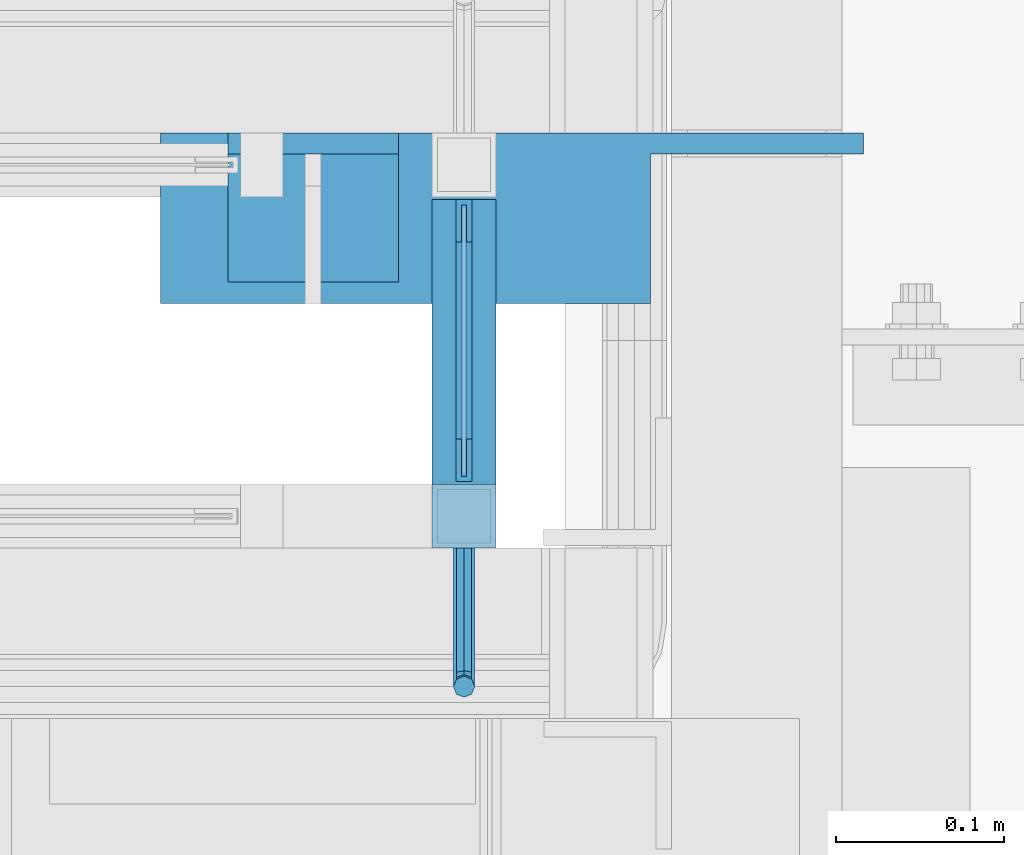
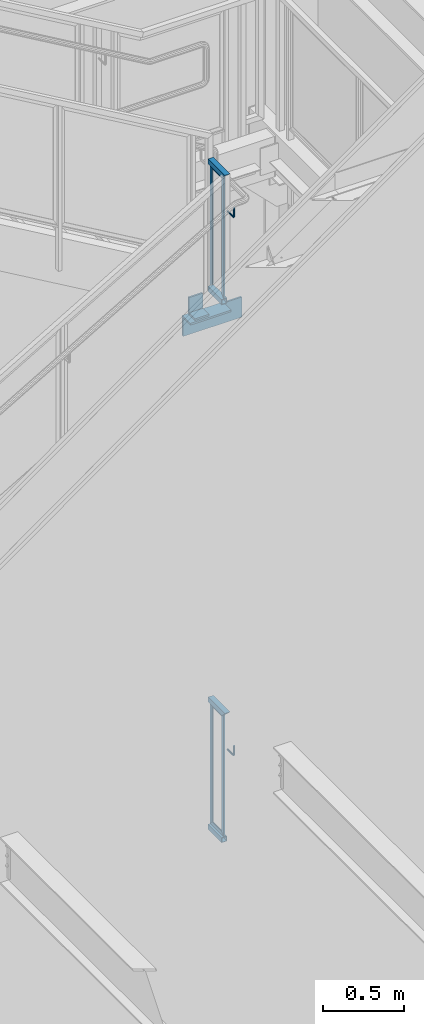
# One storey, part 921 of 1179: 15 beams, 4 elements without a shape of their own.
"""IFC2X3 building model written with IfcOpenShell, lengths in millimetres."""

from ifc_helpers import new_model, si_unit, frame, origin_with_axes, place, context, subcontext, project, spatial, faceted_brep, material, type_object, element, aggregate, save


model = new_model("IFC2X3")

# Units and contexts
model_context = context("Model", 3, precision=1e-05, world=origin_with_axes())
body_context = subcontext(model_context, "Body", "Model", "MODEL_VIEW")
ifc_project = project(units=[si_unit("LENGTHUNIT", "METRE", prefix="MILLI"), si_unit("AREAUNIT", "SQUARE_METRE"), si_unit("VOLUMEUNIT", "CUBIC_METRE"), si_unit("MASSUNIT", "GRAM", prefix="KILO"), si_unit("TIMEUNIT", "SECOND"), si_unit("PLANEANGLEUNIT", "RADIAN"), si_unit("SOLIDANGLEUNIT", "STERADIAN"), si_unit("THERMODYNAMICTEMPERATUREUNIT", "DEGREE_CELSIUS"), si_unit("LUMINOUSINTENSITYUNIT", "LUMEN")], contexts=[model_context])

# Site, building, storey
site_placement = place(None, origin_with_axes())
site = spatial("IfcSite", under=ifc_project, at=site_placement, CompositionType="ELEMENT")
building_placement = place(site_placement, origin_with_axes())
building = spatial("IfcBuilding", under=site, at=building_placement, Name="Undefined", CompositionType="ELEMENT")
storey_placement = place(building_placement, origin_with_axes())
storey = spatial("IfcBuildingStorey", under=building, at=storey_placement, Name="Undefined", CompositionType="ELEMENT", Elevation=0.0)

# Assembly, beams
assembly_1_placement = place(storey_placement, origin_with_axes())
assembly_1 = element("IfcElementAssembly", 1, at=assembly_1_placement, inside=storey, Name="GUARDRAIL", AssemblyPlace="NOTDEFINED", PredefinedType="RIGID_FRAME")
ifc_material_1 = material(Name="STEEL/BUY-OUT")
beam_type_1 = type_object("IfcBeamType", PredefinedType="NOTDEFINED")
beam_1_placement = place(assembly_1_placement, frame((22847.2998865322, 39635.1125005827, 6772.27499990108), z_axis=(0.0, 0.0, -1.0), x_axis=(0.0, 1.0, 0.0)))
beam_1 = element("IfcBeam", 2, at=beam_1_placement, type_object=beam_type_1, material=ifc_material_1, Name="U-EDGE", context=body_context, shape_type="Brep", body=[
    faceted_brep([(0.0, 1.58750000000146, 431.441890042118), (0.0, -1.58750000000146, 431.441890042118), (22.2250001847788, -1.58750000000146, 453.666889346833), (22.2250001847788, -4.76249999999709, 453.666889346833), (3.69283952750266e-07, -4.76249999999709, 431.441890411402), (3.69283952750266e-07, -7.9375, 431.441890411402), (25.4000001847817, -7.9375, 456.841889221109), (25.4000001847817, 1.58750000000146, 456.841889221109), (25.4000001847817, -7.9375, -465.1375), (25.4000001847817, 1.58750000000146, -465.1375), (0.0, 1.58750000000146, -439.737499661022), (0.0, -1.58750000000146, -439.737499661022), (22.2250001847788, -1.58750000000146, -461.962499971525), (22.2250001847788, -4.76249999999709, -461.962499971525), (3.69283952750266e-07, -4.76249999999709, -439.737500030305), (3.69283952750266e-07, -7.9375, -439.737500030305)], [[[0, 1, 2, 3, 4, 5, 6, 7]], [[7, 6, 8, 9]], [[0, 7, 9, 10]], [[1, 0, 10, 11]], [[2, 1, 11, 12]], [[3, 2, 12, 13]], [[4, 3, 13, 14]], [[5, 4, 14, 15]], [[6, 5, 15, 8]], [[14, 13, 12, 11, 10, 9, 8, 15]]]),
])
beam_2_placement = place(assembly_1_placement, frame((22847.2998865322, 39517.6374994016, 6772.27499992234), z_axis=(0.0, 0.0, -1.0), x_axis=(0.0, -1.0, 0.0)))
beam_2 = element("IfcBeam", 3, at=beam_2_placement, type_object=beam_type_1, material=ifc_material_1, Name="U-EDGE", context=body_context, shape_type="Brep", body=[
    faceted_brep([(3.69283952750266e-07, 7.9375, 431.441890420957), (3.69283952750266e-07, 4.76249999999709, 431.441890420957), (22.2250001847788, 4.76249999999709, 453.666889356388), (22.2250001847788, 1.58750000000146, 453.666889356388), (0.0, 1.58750000000146, 431.441890042118), (0.0, -1.58750000000146, 431.441890042118), (25.4000001847817, -1.58750000000146, 456.841889230664), (25.4000001847817, 7.9375, 456.841889230664), (25.4000001847817, -1.58750000000146, -465.1375), (25.4000001847817, 7.9375, -465.1375), (3.69283952750266e-07, 7.9375, -439.7375000303), (3.69283952750266e-07, 4.76249999999709, -439.7375000303), (22.2250001847788, 4.76249999999709, -461.96249997152), (22.2250001847788, 1.58750000000146, -461.96249997152), (0.0, 1.58750000000146, -439.737499661022), (0.0, -1.58750000000146, -439.737499661022)], [[[0, 1, 2, 3, 4, 5, 6, 7]], [[7, 6, 8, 9]], [[0, 7, 9, 10]], [[1, 0, 10, 11]], [[2, 1, 11, 12]], [[3, 2, 12, 13]], [[4, 3, 13, 14]], [[5, 4, 14, 15]], [[6, 5, 15, 8]], [[14, 13, 12, 11, 10, 9, 8, 15]]]),
])
beam_3_placement = place(assembly_1_placement, frame((22847.2998865322, 39557.3250007885, 7212.01249986041), z_axis=(0.0, -1.0, 0.0), x_axis=(0.0, 0.0, 1.0)))
beam_3 = element("IfcBeam", 4, at=beam_3_placement, type_object=beam_type_1, material=ifc_material_1, Name="U-EDGE", context=body_context, shape_type="Brep", body=[
    faceted_brep([(0.0, 1.58750000000146, -77.7875001054272), (22.2250000406702, 1.58750000000146, -100.012500020362), (22.2250000406702, 4.76249999999709, -100.012500020362), (8.10523488325998e-08, 4.76249999999709, -77.7875001864741), (8.10523488325998e-08, 7.9375, -77.7875001864741), (25.4000000406695, 7.9375, -103.1875), (25.4000000406695, -1.58750000000146, -103.1875), (0.0, -1.58750000000146, -77.7875001054272), (25.4000000406695, -1.58750000000146, 65.0875015609199), (0.0, -1.58750000000146, 39.6875016639242), (0.0, 1.58750000000146, 39.6875016639242), (22.2250000406702, 1.58750000000146, 61.9125015788741), (22.2250000406702, 4.76249999999709, 61.9125015788741), (8.10523488325998e-08, 4.76249999999709, 39.6875017449856), (8.10523488325998e-08, 7.9375, 39.6875017449856), (25.4000000406695, 7.9375, 65.0875015609199)], [[[0, 1, 2, 3, 4, 5, 6, 7]], [[7, 6, 8, 9]], [[0, 7, 9, 10]], [[1, 0, 10, 11]], [[2, 1, 11, 12]], [[3, 2, 12, 13]], [[4, 3, 13, 14]], [[5, 4, 14, 15]], [[6, 5, 15, 8]], [[14, 13, 12, 11, 10, 9, 8, 15]]]),
])

assembly_2_placement = place(storey_placement, origin_with_axes())
assembly_2 = element("IfcElementAssembly", 5, at=assembly_2_placement, inside=storey, Name="GUARDRAIL", AssemblyPlace="NOTDEFINED", PredefinedType="RIGID_FRAME")
beam_4_placement = place(assembly_2_placement, frame((22847.2998865322, 39557.3250007739, 2267.30811157115), z_axis=(0.0, -1.0, 0.0), x_axis=(0.0, 0.0, -1.0)))
beam_4 = element("IfcBeam", 6, at=beam_4_placement, type_object=beam_type_1, material=ifc_material_1, Name="U-EDGE", context=body_context, shape_type="Brep", body=[
    faceted_brep([(8.10505298431963e-08, -4.76249999999709, -77.7875001864741), (22.2250000406702, -4.76249999999709, -100.01250002037), (22.2250000406702, -1.58750000000146, -100.01250002037), (0.0, -1.58750000000146, -77.7875001054272), (0.0, 1.58750000000146, -77.7875001054272), (25.4000000406695, 1.58750000000146, -103.1875), (25.4000000406695, -7.9375, -103.1875), (8.10505298431963e-08, -7.9375, -77.7875001864741), (25.4000000406695, -7.9375, 65.0875015609054), (8.10505298431963e-08, -7.9375, 39.6875017449711), (8.10505298431963e-08, -4.76249999999709, 39.6875017449711), (22.2250000406702, -4.76249999999709, 61.9125015788668), (22.2250000406702, -1.58750000000146, 61.9125015788668), (0.0, -1.58750000000146, 39.6875016639242), (0.0, 1.58750000000146, 39.6875016639242), (25.4000000406695, 1.58750000000146, 65.0875015609054)], [[[0, 1, 2, 3, 4, 5, 6, 7]], [[7, 6, 8, 9]], [[0, 7, 9, 10]], [[1, 0, 10, 11]], [[2, 1, 11, 12]], [[3, 2, 12, 13]], [[4, 3, 13, 14]], [[5, 4, 14, 15]], [[6, 5, 15, 8]], [[14, 13, 12, 11, 10, 9, 8, 15]]]),
])
beam_5_placement = place(assembly_2_placement, frame((22847.2998865322, 39635.1125005827, 2698.75000074754), z_axis=(0.0, 0.0, -1.0), x_axis=(0.0, 1.0, 0.0)))
beam_5 = element("IfcBeam", 7, at=beam_5_placement, type_object=beam_type_1, material=ifc_material_1, Name="U-EDGE", context=body_context, shape_type="Brep", body=[
    faceted_brep([(0.0, 1.58750000000146, 431.441890042118), (0.0, -1.58750000000146, 431.441890042118), (22.2250001847788, -1.58750000000146, 453.666889346833), (22.2250001847788, -4.76249999999709, 453.666889346833), (3.69283952750266e-07, -4.76249999999709, 431.441890411402), (3.69283952750266e-07, -7.9375, 431.441890411402), (25.4000001847817, -7.9375, 456.841889221109), (25.4000001847817, 1.58750000000146, 456.841889221109), (25.4000001847817, -7.9375, -465.1375), (25.4000001847817, 1.58750000000146, -465.1375), (0.0, 1.58750000000146, -439.737499661022), (0.0, -1.58750000000146, -439.737499661022), (22.2250001847788, -1.58750000000146, -461.962499971525), (22.2250001847788, -4.76249999999709, -461.962499971525), (3.69283952750266e-07, -4.76249999999709, -439.737500030305), (3.69283952750266e-07, -7.9375, -439.737500030305)], [[[0, 1, 2, 3, 4, 5, 6, 7]], [[7, 6, 8, 9]], [[0, 7, 9, 10]], [[1, 0, 10, 11]], [[2, 1, 11, 12]], [[3, 2, 12, 13]], [[4, 3, 13, 14]], [[5, 4, 14, 15]], [[6, 5, 15, 8]], [[14, 13, 12, 11, 10, 9, 8, 15]]]),
])
beam_6_placement = place(assembly_2_placement, frame((22847.2998865322, 39517.6374994016, 2698.75000076879), z_axis=(0.0, 0.0, -1.0), x_axis=(0.0, -1.0, 0.0)))
beam_6 = element("IfcBeam", 8, at=beam_6_placement, type_object=beam_type_1, material=ifc_material_1, Name="U-EDGE", context=body_context, shape_type="Brep", body=[
    faceted_brep([(3.69283952750266e-07, 7.9375, 431.441890420957), (3.69283952750266e-07, 4.76249999999709, 431.441890420957), (22.2250001847788, 4.76249999999709, 453.666889356388), (22.2250001847788, 1.58750000000146, 453.666889356388), (0.0, 1.58750000000146, 431.441890042118), (0.0, -1.58750000000146, 431.441890042118), (25.4000001847817, -1.58750000000146, 456.841889230664), (25.4000001847817, 7.9375, 456.841889230664), (25.4000001847817, -1.58750000000146, -465.1375), (25.4000001847817, 7.9375, -465.1375), (3.69283952750266e-07, 7.9375, -439.7375000303), (3.69283952750266e-07, 4.76249999999709, -439.7375000303), (22.2250001847788, 4.76249999999709, -461.96249997152), (22.2250001847788, 1.58750000000146, -461.96249997152), (0.0, 1.58750000000146, -439.737499661022), (0.0, -1.58750000000146, -439.737499661022)], [[[0, 1, 2, 3, 4, 5, 6, 7]], [[7, 6, 8, 9]], [[0, 7, 9, 10]], [[1, 0, 10, 11]], [[2, 1, 11, 12]], [[3, 2, 12, 13]], [[4, 3, 13, 14]], [[5, 4, 14, 15]], [[6, 5, 15, 8]], [[14, 13, 12, 11, 10, 9, 8, 15]]]),
])
beam_7_placement = place(assembly_2_placement, frame((22847.2998865322, 39557.3250007885, 3138.48750070686), z_axis=(0.0, -1.0, 0.0), x_axis=(0.0, 0.0, 1.0)))
beam_7 = element("IfcBeam", 9, at=beam_7_placement, type_object=beam_type_1, material=ifc_material_1, Name="U-EDGE", context=body_context, shape_type="Brep", body=[
    faceted_brep([(0.0, 1.58750000000146, -77.7875001054272), (22.2250000406702, 1.58750000000146, -100.012500020362), (22.2250000406702, 4.76249999999709, -100.012500020362), (8.10523488325998e-08, 4.76249999999709, -77.7875001864741), (8.10523488325998e-08, 7.9375, -77.7875001864741), (25.4000000406695, 7.9375, -103.1875), (25.4000000406695, -1.58750000000146, -103.1875), (0.0, -1.58750000000146, -77.7875001054272), (25.4000000406695, -1.58750000000146, 65.0875015609199), (0.0, -1.58750000000146, 39.6875016639242), (0.0, 1.58750000000146, 39.6875016639242), (22.2250000406702, 1.58750000000146, 61.9125015788741), (22.2250000406702, 4.76249999999709, 61.9125015788741), (8.10523488325998e-08, 4.76249999999709, 39.6875017449856), (8.10523488325998e-08, 7.9375, 39.6875017449856), (25.4000000406695, 7.9375, 65.0875015609199)], [[[0, 1, 2, 3, 4, 5, 6, 7]], [[7, 6, 8, 9]], [[0, 7, 9, 10]], [[1, 0, 10, 11]], [[2, 1, 11, 12]], [[3, 2, 12, 13]], [[4, 3, 13, 14]], [[5, 4, 14, 15]], [[6, 5, 15, 8]], [[14, 13, 12, 11, 10, 9, 8, 15]]]),
])
ifc_material_2 = material(Name="STEEL/A36")
beam_type_2 = type_object("IfcBeamType", PredefinedType="NOTDEFINED")
beam_8_placement = place(assembly_2_placement, frame((22844.1248872988, 39452.5499999814, 2928.39731675587), z_axis=(0.0, 0.0, 1.0), x_axis=(0.0, -1.0, 0.0)))
beam_8 = element("IfcBeam", 10, at=beam_8_placement, type_object=beam_type_2, material=ifc_material_2, Name="BRACKET", context=body_context, shape_type="Brep", body=[
    faceted_brep([(0.0, 0.0, 6.34999999999991), (0.0, -4.49012806053361, 4.49012806053452), (69.849999425729, -4.49012806053361, 4.49012806053452), (69.849999425729, 0.0, 6.34999999999991), (0.0, 4.49012806053361, 4.49012806053452), (69.849999425729, 4.49012806053361, 4.49012806053452), (0.0, 6.34999999999854, 0.0), (69.849999425729, 6.34999999999854, 0.0), (0.0, 4.49012806053361, -4.49012806053452), (69.849999425729, 4.49012806053361, -4.49012806053452), (0.0, 0.0, -6.34999999999991), (69.849999425729, 0.0, -6.34999999999991), (0.0, -4.49012806053361, -4.49012806053452), (69.849999425729, -4.49012806053361, -4.49012806053452), (0.0, -6.34999999999854, 0.0), (69.849999425729, -6.34999999999854, 0.0), (76.1999993303689, -6.34999999999854, 1.70147734638658), (73.9549353000984, -4.49012806053361, 5.59004231305425), (73.024999330366, 0.0, 7.20073866041639), (73.9549353000984, 4.49012806053361, 5.59004231305425), (76.1999993303689, 6.34999999999854, 1.70147734638658), (78.445063360632, 4.49012806053361, -2.18708762028064), (79.3749993303718, 0.0, -3.79778396764323), (78.445063360632, -4.49012806053361, -2.18708762028064), (84.7370868552753, 4.49012806053361, 4.10493587436031), (87.0401272955278, 4.49012806053361, 12.6999998092651), (88.8999992349927, 0.0, 12.6999998092651), (86.3477832026401, 0.0, 3.17499990462693), (80.8485218886053, 6.34999999999854, 6.34999990462893), (82.5499992349942, 6.34999999999854, 12.6999998092651), (76.9599569219426, 4.49012806053361, 8.59506393489755), (78.0598711744606, 4.49012806053361, 12.6999998092651), (75.3492605745778, 0.0, 9.52499990463093), (76.1999992349956, 0.0, 12.6999998092651), (76.9599569219426, -4.49012806053361, 8.59506393489755), (78.0598711744606, -4.49012806053361, 12.6999998092651), (80.8485218886053, -6.34999999999854, 6.34999990462893), (82.5499992349942, -6.34999999999854, 12.6999998092651), (84.7370868552753, -4.49012806053361, 4.10493587436031), (87.0401272955278, -4.49012806053361, 12.6999998092651), (88.8999992349927, 0.0, 76.2000000000003), (87.0401280961523, -4.4901280621234, 73.5807586148453), (82.5500000355751, -6.35000000147556, 72.4958333104305), (78.0598719750778, -4.4901280619415, 73.5807586149517), (76.1999992349956, 0.0, 76.2000000000003), (78.0598719752597, 4.49012805902021, 78.8192413833694), (82.550000035837, 6.34999999837237, 79.9041666931562), (87.0401280963342, 4.49012805883831, 78.819241383263)], [[[0, 1, 2, 3]], [[4, 0, 3, 5]], [[6, 4, 5, 7]], [[8, 6, 7, 9]], [[10, 8, 9, 11]], [[12, 10, 11, 13]], [[1, 0, 4, 6, 8, 10, 12, 14]], [[1, 14, 15, 2]], [[14, 12, 13, 15]], [[2, 15, 16, 17]], [[3, 2, 17, 18]], [[5, 3, 18, 19]], [[7, 5, 19, 20]], [[9, 7, 20, 21]], [[11, 9, 21, 22]], [[13, 11, 22, 23]], [[24, 25, 26, 27]], [[28, 29, 25, 24]], [[30, 31, 29, 28]], [[32, 33, 31, 30]], [[34, 35, 33, 32]], [[36, 37, 35, 34]], [[38, 39, 37, 36]], [[27, 26, 39, 38]], [[22, 27, 38, 23]], [[21, 24, 27, 22]], [[20, 28, 24, 21]], [[19, 30, 28, 20]], [[18, 32, 30, 19]], [[17, 34, 32, 18]], [[16, 36, 34, 17]], [[23, 38, 36, 16]], [[15, 13, 23, 16]], [[39, 26, 40, 41]], [[37, 39, 41, 42]], [[35, 37, 42, 43]], [[33, 35, 43, 44]], [[31, 33, 44, 45]], [[29, 31, 45, 46]], [[25, 29, 46, 47]], [[26, 25, 47, 40]], [[46, 45, 44, 43, 42, 41, 40, 47]]]),
])

# Beam
beam_9_placement = place(assembly_1_placement, frame((22844.1250009065, 39452.5499992245, 7001.83950773577), z_axis=(0.0, 0.0, 1.0), x_axis=(0.0, -1.0, 0.0)))
beam_9 = element("IfcBeam", 11, at=beam_9_placement, type_object=beam_type_2, material=ifc_material_2, Name="BRACKET", context=body_context, shape_type="Brep", body=[
    faceted_brep([(0.0, 0.0, 6.34999999999991), (0.0, -4.49012806053361, 4.49012806053452), (69.849999425729, -4.49012806053361, 4.49012806053452), (69.849999425729, 0.0, 6.34999999999991), (0.0, 4.49012806053361, 4.49012806053452), (69.849999425729, 4.49012806053361, 4.49012806053452), (0.0, 6.34999999999854, 0.0), (69.849999425729, 6.34999999999854, 0.0), (0.0, 4.49012806053361, -4.49012806053452), (69.849999425729, 4.49012806053361, -4.49012806053452), (0.0, 0.0, -6.34999999999991), (69.849999425729, 0.0, -6.34999999999991), (0.0, -4.49012806053361, -4.49012806053452), (69.849999425729, -4.49012806053361, -4.49012806053452), (0.0, -6.34999999999854, 0.0), (69.849999425729, -6.34999999999854, 0.0), (76.1999993303689, -6.34999999999854, 1.70147734638658), (73.9549353000984, -4.49012806053361, 5.59004231305425), (73.024999330366, 0.0, 7.20073866041639), (73.9549353000984, 4.49012806053361, 5.59004231305425), (76.1999993303689, 6.34999999999854, 1.70147734638658), (78.445063360632, 4.49012806053361, -2.18708762028064), (79.3749993303718, 0.0, -3.79778396764323), (78.445063360632, -4.49012806053361, -2.18708762028064), (84.7370868552753, 4.49012806053361, 4.10493587436031), (87.0401272955278, 4.49012806053361, 12.6999998092651), (88.8999992349927, 0.0, 12.6999998092651), (86.3477832026401, 0.0, 3.17499990462693), (80.8485218886053, 6.34999999999854, 6.34999990462893), (82.5499992349942, 6.34999999999854, 12.6999998092651), (76.9599569219426, 4.49012806053361, 8.59506393489755), (78.0598711744606, 4.49012806053361, 12.6999998092651), (75.3492605745778, 0.0, 9.52499990463093), (76.1999992349956, 0.0, 12.6999998092651), (76.9599569219426, -4.49012806053361, 8.59506393489755), (78.0598711744606, -4.49012806053361, 12.6999998092651), (80.8485218886053, -6.34999999999854, 6.34999990462893), (82.5499992349942, -6.34999999999854, 12.6999998092651), (84.7370868552753, -4.49012806053361, 4.10493587436031), (87.0401272955278, -4.49012806053361, 12.6999998092651), (88.8999992349927, 0.0, 76.2000000000003), (87.0401280961523, -4.4901280621234, 73.5807586148453), (82.5500000355751, -6.35000000147556, 72.4958333104305), (78.0598719750778, -4.4901280619415, 73.5807586149517), (76.1999992349956, 0.0, 76.2000000000003), (78.0598719752597, 4.49012805902021, 78.8192413833694), (82.550000035837, 6.34999999837237, 79.9041666931562), (87.0401280963342, 4.49012805883831, 78.819241383263)], [[[0, 1, 2, 3]], [[4, 0, 3, 5]], [[6, 4, 5, 7]], [[8, 6, 7, 9]], [[10, 8, 9, 11]], [[12, 10, 11, 13]], [[1, 0, 4, 6, 8, 10, 12, 14]], [[1, 14, 15, 2]], [[14, 12, 13, 15]], [[2, 15, 16, 17]], [[3, 2, 17, 18]], [[5, 3, 18, 19]], [[7, 5, 19, 20]], [[9, 7, 20, 21]], [[11, 9, 21, 22]], [[13, 11, 22, 23]], [[24, 25, 26, 27]], [[28, 29, 25, 24]], [[30, 31, 29, 28]], [[32, 33, 31, 30]], [[34, 35, 33, 32]], [[36, 37, 35, 34]], [[38, 39, 37, 36]], [[27, 26, 39, 38]], [[22, 27, 38, 23]], [[21, 24, 27, 22]], [[20, 28, 24, 21]], [[19, 30, 28, 20]], [[18, 32, 30, 19]], [[17, 34, 32, 18]], [[16, 36, 34, 17]], [[23, 38, 36, 16]], [[15, 13, 23, 16]], [[39, 26, 40, 41]], [[37, 39, 41, 42]], [[35, 37, 42, 43]], [[33, 35, 43, 44]], [[31, 33, 44, 45]], [[29, 31, 45, 46]], [[25, 29, 46, 47]], [[26, 25, 47, 40]], [[46, 45, 44, 43, 42, 41, 40, 47]]]),
])

ifc_material_3 = material()
beam_type_3 = type_object("IfcBeamType", Name="HSS1-1/2X1-1/2X1/8", PredefinedType="NOTDEFINED")
beam_10_placement = place(assembly_1_placement, frame((22844.1250009048, 39471.6001646336, 6294.79561144198), z_axis=(-1.0, 0.0, 0.0), x_axis=(0.0, 1.0, 0.0)))
beam_10 = element("IfcBeam", 12, at=beam_10_placement, type_object=beam_type_3, material=ifc_material_3, Name="POST", ObjectType="HSS1-1/2X1-1/2X1/8", context=body_context, shape_type="Brep", body=[
    faceted_brep([(19.0498345913293, -19.0499992349996, 19.0499999999993), (19.0498345913293, 19.0499992349996, 19.0499992350015), (19.0498345913293, 19.0499992349996, -19.0499992350015), (19.0498345913293, -19.0499992349996, -19.0499992350015), (19.0498345913293, -15.8749992829999, 15.8749992830017), (19.0498345913293, -15.8749992829999, -15.8749992830017), (19.0498345913293, 15.8749992829999, -15.8749992830017), (19.0498345913293, 15.8749992829999, 15.8749992830017), (188.912499999999, 19.0499992349996, -19.0499992350015), (188.912499999999, -19.0499992349996, -19.0499992350015), (188.912499999999, -19.0499992349996, 19.0499992350015), (188.912499999999, 19.0499992349996, 19.0499992350015), (188.912499999999, -15.8749992829999, 15.8749992830017), (188.912499999999, 15.8749992829999, 15.8749992830017), (188.912499999999, 15.8749992829999, -15.8749992830017), (188.912499999999, -15.8749992829999, -15.8749992830017)], [[[0, 1, 2, 3], [4, 5, 6, 7]], [[8, 9, 3, 2]], [[9, 10, 0, 3]], [[10, 11, 1, 0]], [[11, 8, 2, 1]], [[10, 9, 8, 11], [12, 13, 14, 15]], [[13, 12, 4, 7]], [[14, 13, 7, 6]], [[15, 14, 6, 5]], [[12, 15, 5, 4]]]),
])

beam_11_placement = place(assembly_1_placement, frame((22844.1250009048, 39471.5999992249, 7258.04999915355), z_axis=(-1.0, 0.0, 0.0), x_axis=(0.0, 1.0, 0.0)))
beam_11 = element("IfcBeam", 13, at=beam_11_placement, type_object=beam_type_3, material=ifc_material_3, Name="POST", ObjectType="HSS1-1/2X1-1/2X1/8", context=body_context, shape_type="Brep", body=[
    faceted_brep([(15.874999282998, 15.874999282998, -15.8749992829999), (-15.8749985180002, -15.8749992829999, -15.874999282998), (188.912499999999, -15.8749992829999, -15.8749992830017), (188.912499999999, 15.8749992829999, -15.8749992830017), (-15.8749992830017, -15.874999282998, 15.8749992829999), (188.912499999999, -15.8749992829999, 15.8749992830017), (15.8750000479995, 15.8749992829999, 15.874999282998), (188.912499999999, 15.8749992829999, 15.8749992830017), (19.0499999999993, 19.0499992349996, -19.0499992350015), (19.0499999999993, 19.0499992349996, 19.0499992350015), (188.912499999999, 19.0499992349996, 19.0499992350015), (188.912499999999, 19.0499992349996, -19.0499992350015), (-19.0499992350015, -19.0499992350015, 19.0499992349996), (188.912499999999, -19.0499992349996, 19.0499992350015), (-19.04999847, -19.0499992349996, -19.0499992350015), (188.912499999999, -19.0499992349996, -19.0499992350015)], [[[0, 1, 2, 3]], [[1, 4, 5, 2]], [[4, 6, 7, 5]], [[6, 0, 3, 7]], [[8, 9, 10, 11]], [[9, 12, 13, 10]], [[12, 14, 15, 13]], [[14, 8, 11, 15]], [[13, 15, 11, 10], [5, 7, 3, 2]], [[14, 12, 9, 8], [6, 4, 1, 0]]]),
])

aggregate(assembly_1, [beam_1, beam_2, beam_3, beam_9, beam_10, beam_11])

beam_12_placement = place(assembly_2_placement, frame((22844.1248872972, 39471.6001653905, 2221.27061229789), z_axis=(-1.0, 0.0, 0.0), x_axis=(0.0, 1.0, 0.0)))
beam_12 = element("IfcBeam", 14, at=beam_12_placement, type_object=beam_type_3, material=ifc_material_3, Name="POST", ObjectType="HSS1-1/2X1-1/2X1/8", context=body_context, shape_type="Brep", body=[
    faceted_brep([(19.0498345913293, -19.0499992349996, 19.0499999999993), (19.0498345913293, 19.0499992349996, 19.0499992350015), (19.0498345913293, 19.0499992349996, -19.0499992350015), (19.0498345913293, -19.0499992349996, -19.0499992350015), (19.0498345913293, -15.8749992829999, 15.8749992830017), (19.0498345913293, -15.8749992829999, -15.8749992830017), (19.0498345913293, 15.8749992829999, -15.8749992830017), (19.0498345913293, 15.8749992829999, 15.8749992830017), (188.912335387467, 19.0499992350001, -19.0499992350015), (188.912335387467, -19.0499992350001, -19.0499992350015), (188.912335387467, -19.0499992350001, 19.0499992350015), (188.912335387467, 19.0499992350001, 19.0499992350015), (188.912335387467, -15.8749992829999, 15.8749992830017), (188.912335387467, 15.8749992829999, 15.8749992830017), (188.912335387467, 15.8749992829999, -15.8749992830017), (188.912335387467, -15.8749992829999, -15.8749992830017)], [[[0, 1, 2, 3], [4, 5, 6, 7]], [[8, 9, 3, 2]], [[9, 10, 0, 3]], [[10, 11, 1, 0]], [[11, 8, 2, 1]], [[10, 9, 8, 11], [12, 13, 14, 15]], [[13, 12, 4, 7]], [[14, 13, 7, 6]], [[15, 14, 6, 5]], [[12, 15, 5, 4]]]),
])

beam_13_placement = place(assembly_2_placement, frame((22844.1248872972, 39471.5999999818, 3184.525), z_axis=(-1.0, 0.0, 0.0), x_axis=(0.0, 1.0, 0.0)))
beam_13 = element("IfcBeam", 15, at=beam_13_placement, type_object=beam_type_3, material=ifc_material_3, Name="POST", ObjectType="HSS1-1/2X1-1/2X1/8", context=body_context, shape_type="Brep", body=[
    faceted_brep([(15.874999282998, 15.874999282998, -15.8749992829999), (-15.8749985180002, -15.8749992829999, -15.874999282998), (188.912499999999, -15.8749992829999, -15.8749992830017), (188.912499999999, 15.8749992829999, -15.8749992830017), (-15.8749992830017, -15.874999282998, 15.8749992829999), (188.912499999999, -15.8749992829999, 15.8749992830017), (15.8750000479995, 15.8749992829999, 15.874999282998), (188.912499999999, 15.8749992829999, 15.8749992830017), (19.0499999999993, 19.0499992349996, -19.0499992350015), (19.0499999999993, 19.0499992349996, 19.0499992350015), (188.912499999999, 19.0499992349996, 19.0499992350015), (188.912499999999, 19.0499992349996, -19.0499992350015), (-19.0499992350015, -19.0499992350015, 19.0499992349996), (188.912499999999, -19.0499992349996, 19.0499992350015), (-19.04999847, -19.0499992349996, -19.0499992350015), (188.912499999999, -19.0499992349996, -19.0499992350015)], [[[0, 1, 2, 3]], [[1, 4, 5, 2]], [[4, 6, 7, 5]], [[6, 0, 3, 7]], [[8, 9, 10, 11]], [[9, 12, 13, 10]], [[12, 14, 15, 13]], [[14, 8, 11, 15]], [[13, 15, 11, 10], [5, 7, 3, 2]], [[14, 12, 9, 8], [6, 4, 1, 0]]]),
])

aggregate(assembly_2, [beam_4, beam_5, beam_8, beam_6, beam_7, beam_12, beam_13])

# Assembly, beam
assembly_3_placement = place(storey_placement, origin_with_axes())
assembly_3 = element("IfcElementAssembly", 16, at=assembly_3_placement, inside=storey, Name="ANGLE", AssemblyPlace="NOTDEFINED", PredefinedType="RIGID_FRAME")
beam_type_4 = type_object("IfcBeamType", Name="L5X3-1/2X1/2", PredefinedType="NOTDEFINED")
beam_14_placement = place(assembly_3_placement, frame((22703.2939505092, 39655.7500000355, 6188.67000099707), z_axis=(0.0, 0.0, 1.0), x_axis=(1.0, 0.0, 0.0)))
beam_14 = element("IfcBeam", 17, at=beam_14_placement, type_object=beam_type_4, material=ifc_material_2, Name="ANGLE", ObjectType="L5X3-1/2X1/2", context=body_context, shape_type="Brep", body=[
    faceted_brep([(0.0, 44.4499999999971, -63.5), (0.0, 44.4499999999971, 63.5), (101.599999999999, 44.4499999999971, 63.5), (101.599999999999, 44.4499999999971, -63.5), (0.0, 31.75, 63.5), (101.599999999999, 31.75, 63.5), (0.0, 31.75, -50.8000000000002), (101.599999999999, 31.75, -50.8000000000002), (0.0, -44.4499999999971, -50.8000000000002), (101.599999999999, -44.4499999999971, -50.8000000000002), (0.0, -44.4499999999971, -63.5), (101.599999999999, -44.4499999999971, -63.5)], [[[0, 1, 2, 3]], [[1, 4, 5, 2]], [[4, 6, 7, 5]], [[6, 8, 9, 7]], [[8, 10, 11, 9]], [[10, 0, 3, 11]], [[5, 7, 9, 11, 3, 2]], [[10, 8, 6, 4, 1, 0]]]),
])
aggregate(assembly_3, [beam_14])

assembly_4_placement = place(storey_placement, origin_with_axes())
assembly_4 = element("IfcElementAssembly", 18, at=assembly_4_placement, inside=storey, Name="ANGLE", AssemblyPlace="NOTDEFINED", PredefinedType="RIGID_FRAME")
beam_type_5 = type_object("IfcBeamType", Name="L6X4X1/2", PredefinedType="NOTDEFINED")
beam_15_placement = place(assembly_4_placement, frame((23082.2500006927, 39649.3999999582, 6048.97000099708), z_axis=(0.0, 0.0, -1.0), x_axis=(-1.0, 0.0, 0.0)))
beam_15 = element("IfcBeam", 19, at=beam_15_placement, type_object=beam_type_5, material=ifc_material_2, Name="ANGLE", ObjectType="L6X4X1/2", context=body_context, shape_type="Brep", body=[
    faceted_brep([(0.0, 38.0999999999985, -63.5), (0.0, 38.0999999999985, -76.1999999999998), (127.0, 38.0999999999985, -76.1999999999998), (127.0, 38.0999999999985, -63.5), (127.0, -50.8000000000029, -63.5), (127.0, -50.8000000000029, -76.1999999999998), (419.099999999999, -50.8000000000029, -76.1999999999998), (419.099999999999, -50.8000000000029, -63.5), (0.0, 50.8000000000029, -76.1999999999998), (419.099999999999, 50.8000000000029, -76.1999999999998), (0.0, 38.0999999999985, 76.1999999999998), (0.0, 50.8000000000029, 76.1999999999998), (127.0, 38.0999999999985, 76.1999999999998), (419.099999999999, 38.0999999999985, 76.1999999999998), (419.099999999999, 50.8000000000029, 76.1999999999998), (419.099999999999, 38.0999999999985, -63.5)], [[[0, 1, 2, 3]], [[4, 3, 2, 5]], [[6, 7, 4, 5]], [[1, 8, 9, 6, 5, 2]], [[10, 11, 8, 1, 0]], [[11, 10, 12, 13, 14]], [[8, 11, 14, 9]], [[13, 15, 7, 6, 9, 14]], [[12, 10, 0, 3, 15, 13]], [[7, 15, 3, 4]]]),
])
aggregate(assembly_4, [beam_15])

save(model, "model.ifc")
